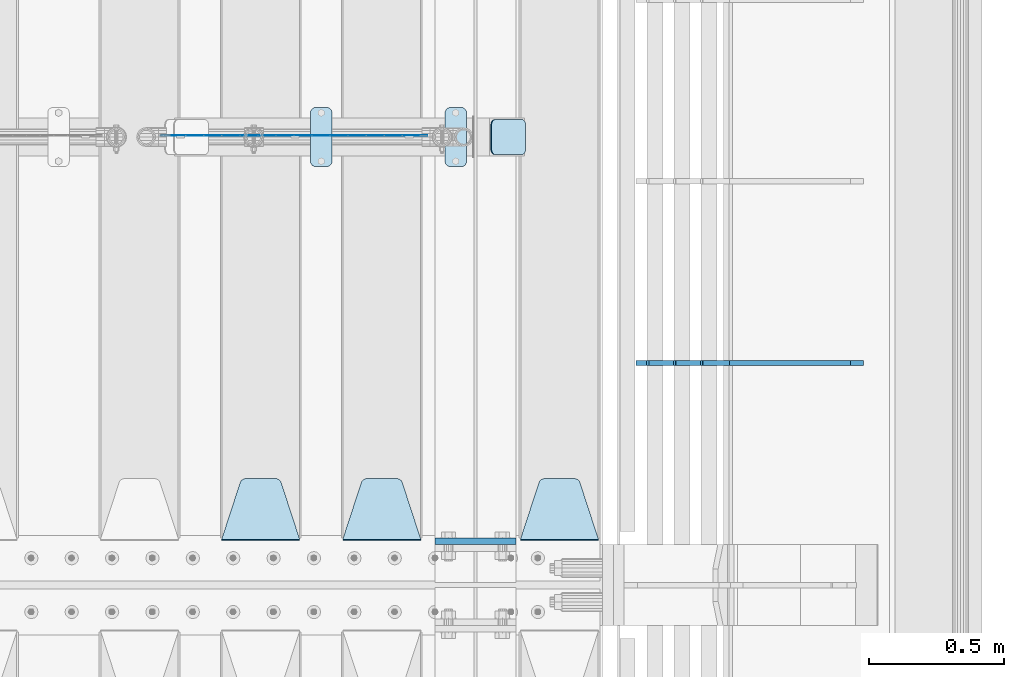
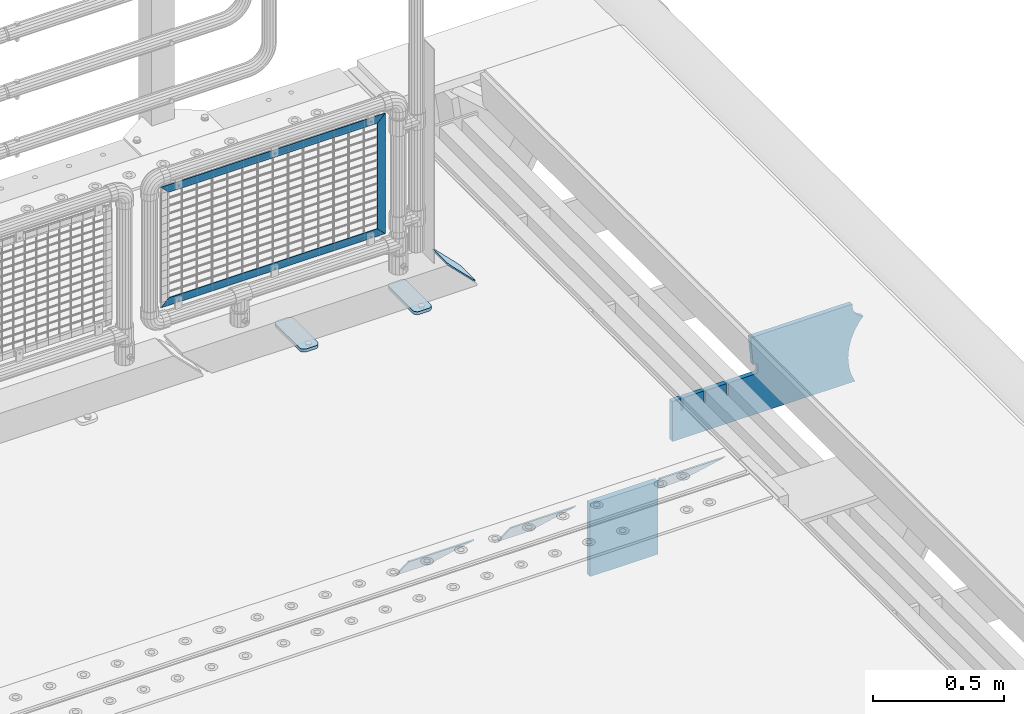
# One storey, part 225 of 242: 11 plates.
"""IFC2X3 building model written with IfcOpenShell, lengths in millimetres."""

import ifcopenshell
import ifcopenshell.guid

model = None  # the IFC model being written
_history = None  # IfcOwnerHistory: only IFC2X3 demands one
_inside = {}  # id of a spatial element -> (the spatial element, [elements in it])
_under = {}  # id of a project, library or spatial element -> (it, [spatial elements below it])
_declared = {}  # id of a project -> (the project, [libraries it declares])
_typed = {}  # id of a type object -> (the type object, [elements of that type])
_made_of = {}  # id of a material, layer set ... -> (it, [elements and type objects made of it])


def new_model(schema):
    """Start an empty IFC model of exactly this schema.

    Asked for "IFC4X3", IfcOpenShell would pick the latest addendum, in which some entities
    have other attributes; the version numbers below select the first issue.
    IFC2X3 requires an IfcOwnerHistory on every rooted entity: one is made here for all.
    """
    global model, _history
    if schema == "IFC4X3":
        model = ifcopenshell.file(schema_version=(4, 3, 0, 0))
    else:
        model = ifcopenshell.file(schema=schema)
    _inside.clear()
    _under.clear()
    _declared.clear()
    _typed.clear()
    _made_of.clear()
    _history = None
    if model.schema == "IFC2X3":
        org = make("IfcOrganization", Name="unknown")
        user = make(
            "IfcPersonAndOrganization",
            ThePerson=make("IfcPerson", FamilyName="unknown"),
            TheOrganization=org,
        )
        app = make(
            "IfcApplication",
            ApplicationDeveloper=org,
            Version="unknown",
            ApplicationFullName="unknown",
            ApplicationIdentifier="unknown",
        )
        _history = make(
            "IfcOwnerHistory",
            OwningUser=user,
            OwningApplication=app,
            ChangeAction="ADDED",
            CreationDate=0,
        )
    return model


def make(cls, **values):
    """One entity of the class cls with the attributes given. An attribute that is None is left unset."""
    return model.create_entity(
        cls, **{name: value for name, value in values.items() if value is not None}
    )


def rooted(cls, **values):
    """An entity with a GlobalId (a new one), such as an element, a storey or a relation."""
    return make(cls, GlobalId=ifcopenshell.guid.new(), OwnerHistory=_history, **values)


def si_unit(unit_type, name, prefix=None):
    """IfcSIUnit, for example si_unit("LENGTHUNIT", "METRE", prefix="MILLI")."""
    return make("IfcSIUnit", UnitType=unit_type, Prefix=prefix, Name=name)


def assignment(units):
    """IfcUnitAssignment: the units of a project."""
    return None if units is None else make("IfcUnitAssignment", Units=units)


def point(xyz):
    """IfcCartesianPoint."""
    return None if xyz is None else make("IfcCartesianPoint", Coordinates=xyz)


def direction(xyz):
    """IfcDirection."""
    return None if xyz is None else make("IfcDirection", DirectionRatios=xyz)


def frame(location, z_axis=None, x_axis=None):
    """IfcAxis2Placement3D, a coordinate frame: its origin and axes. An axis left out is left unset."""
    return make(
        "IfcAxis2Placement3D",
        Location=point(location),
        Axis=direction(z_axis),
        RefDirection=direction(x_axis),
    )


def origin_with_axes():
    """The frame at (0, 0, 0) with the z axis (0, 0, 1) and the x axis (1, 0, 0) written out."""
    return frame((0.0, 0.0, 0.0), z_axis=(0.0, 0.0, 1.0), x_axis=(1.0, 0.0, 0.0))


def place(relative_to, where):
    """IfcLocalPlacement: puts the frame where relative to a parent placement (None: the world)."""
    return make(
        "IfcLocalPlacement", PlacementRelTo=relative_to, RelativePlacement=where
    )


def context(
    kind, dimensions, precision=None, world=None, true_north=None, identifier=None
):
    """IfcGeometricRepresentationContext, for example the 3D "Model" context."""
    return make(
        "IfcGeometricRepresentationContext",
        ContextIdentifier=identifier,
        ContextType=kind,
        CoordinateSpaceDimension=dimensions,
        Precision=precision,
        WorldCoordinateSystem=world,
        TrueNorth=true_north,
    )


def subcontext(parent, identifier, kind, view, scale=None):
    """IfcGeometricRepresentationSubContext, for example "Body" below "Model"."""
    return make(
        "IfcGeometricRepresentationSubContext",
        ContextIdentifier=identifier,
        ContextType=kind,
        ParentContext=parent,
        TargetScale=scale,
        TargetView=view,
    )


def project(units=None, contexts=None):
    """IfcProject with its units and contexts."""
    return rooted(
        "IfcProject",
        Name="project",
        RepresentationContexts=contexts,
        UnitsInContext=assignment(units),
    )


def spatial(cls, under=None, at=None, **own):
    """A site, building, storey or space (cls), placed at a placement, below another one or the project."""
    s = rooted(cls, ObjectPlacement=at, **own)
    if under is not None:
        _under.setdefault(under.id(), (under, []))[1].append(s)
    return s


def faces_of(points, faces, orient=None, outer=None):
    """IfcFace entities. A face is a list of loops; a loop is a list of indices into points, from 0.

    orient and outer hold one flag for each loop. By default every Orientation is true, the
    first loop of a face is its IfcFaceOuterBound and the others are IfcFaceBound.
    """
    made = []
    for i, loops in enumerate(faces):
        bounds = []
        for j, loop in enumerate(loops):
            is_outer = j == 0 if outer is None else outer[i][j]
            bounds.append(
                make(
                    "IfcFaceOuterBound" if is_outer else "IfcFaceBound",
                    Bound=make("IfcPolyLoop", Polygon=[points[k] for k in loop]),
                    Orientation=True if orient is None else orient[i][j],
                )
            )
        made.append(make("IfcFace", Bounds=bounds))
    return made


def faceted_brep(points, faces, orient=None, outer=None, voids=None):
    """IfcFacetedBrep: a solid bounded by flat faces; with voids (closed shells), ...WithVoids."""
    shared = [point(p) for p in points]
    hull = make("IfcClosedShell", CfsFaces=faces_of(shared, faces, orient, outer))
    if voids is None:
        return make("IfcFacetedBrep", Outer=hull)
    return make(
        "IfcFacetedBrepWithVoids",
        Outer=hull,
        Voids=[
            make(cls, CfsFaces=faces_of(shared, fs, o, b)) for cls, fs, o, b in voids
        ],
    )


def shape(context_of_items, identifier, shape_type, items):
    """IfcShapeRepresentation: the items that make up one representation, for example the "Body"."""
    return make(
        "IfcShapeRepresentation",
        ContextOfItems=context_of_items,
        RepresentationIdentifier=identifier,
        RepresentationType=shape_type,
        Items=items,
    )


def material(Name=None, Category=None):
    """IfcMaterial."""
    return make("IfcMaterial", Name=Name, Category=Category)


def made_of(thing, what):
    """Note that an element or type object is made of a material, layer set ...; save() writes the relation."""
    if what is not None:
        _made_of.setdefault(what.id(), (what, []))[1].append(thing)
    return thing


def type_object(cls, material=None, **own):
    """A type object (cls), such as IfcWallType, which elements share."""
    return made_of(rooted(cls, **own), material)


def element(
    cls,
    number,
    at=None,
    inside=None,
    cuts=None,
    type_object=None,
    material=None,
    context=None,
    identifier="Body",
    shape_type=None,
    held_by="IfcProductDefinitionShape",
    body=None,
    shapes=None,
    **own,
):
    """One element of the class cls, such as IfcWall. Its Tag is "e" and its number.

    at: its placement. inside: the storey or other place that contains it. cuts: it is an
    opening in that element (IfcRelVoidsElement). A single representation is given by context,
    identifier, shape_type and body (its items); several are given by shapes. held_by: the class
    of the entity that holds the representations. save() writes the other relations.
    """
    e = rooted(cls, Tag="e%d" % number, ObjectPlacement=at, **own)
    if body is not None:
        shapes = [shape(context, identifier, shape_type, body)]
    if shapes is not None:
        e.Representation = make(held_by, Representations=shapes)
    if inside is not None:
        _inside.setdefault(inside.id(), (inside, []))[1].append(e)
    if cuts is not None:
        rooted(
            "IfcRelVoidsElement", RelatingBuildingElement=cuts, RelatedOpeningElement=e
        )
    if type_object is not None:
        _typed.setdefault(type_object.id(), (type_object, []))[1].append(e)
    return made_of(e, material)


def aggregate(whole, parts):
    """IfcRelAggregates: a whole, such as a stair, and the parts it consists of."""
    return rooted("IfcRelAggregates", RelatingObject=whole, RelatedObjects=parts)


def save(model, path):
    """Write the relations noted so far, then the file.

    IfcRelAggregates (storeys below a building ...), IfcRelContainedInSpatialStructure (elements
    in a storey), IfcRelDefinesByType, IfcRelAssociatesMaterial and IfcRelDeclares: one each for
    every whole, place, type object, material and project.
    """
    for whole, parts in _under.values():
        aggregate(whole, parts)
    for where, things in _inside.values():
        rooted(
            "IfcRelContainedInSpatialStructure",
            RelatedElements=things,
            RelatingStructure=where,
        )
    for kind, things in _typed.values():
        rooted("IfcRelDefinesByType", RelatedObjects=things, RelatingType=kind)
    for what, things in _made_of.values():
        rooted("IfcRelAssociatesMaterial", RelatedObjects=things, RelatingMaterial=what)
    for by, libraries in _declared.values():
        rooted("IfcRelDeclares", RelatingContext=by, RelatedDefinitions=libraries)
    model.write(path)


model = new_model("IFC2X3")

# Units and contexts
model_context = context("Model", 3, precision=1e-05, world=origin_with_axes())
body_context = subcontext(model_context, "Body", "Model", "MODEL_VIEW")
ifc_project = project(units=[si_unit("LENGTHUNIT", "METRE", prefix="MILLI"), si_unit("AREAUNIT", "SQUARE_METRE"), si_unit("VOLUMEUNIT", "CUBIC_METRE"), si_unit("MASSUNIT", "GRAM", prefix="KILO"), si_unit("TIMEUNIT", "SECOND"), si_unit("PLANEANGLEUNIT", "RADIAN"), si_unit("SOLIDANGLEUNIT", "STERADIAN"), si_unit("THERMODYNAMICTEMPERATUREUNIT", "DEGREE_CELSIUS"), si_unit("LUMINOUSINTENSITYUNIT", "LUMEN")], contexts=[model_context])

# Site, building, storey
site_placement = place(None, origin_with_axes())
site = spatial("IfcSite", under=ifc_project, at=site_placement, CompositionType="ELEMENT")
building_placement = place(site_placement, origin_with_axes())
building = spatial("IfcBuilding", under=site, at=building_placement, Name="Standard", CompositionType="ELEMENT")
storey_placement = place(building_placement, origin_with_axes())
storey = spatial("IfcBuildingStorey", under=building, at=storey_placement, Name="Undefined", CompositionType="ELEMENT", Elevation=0.0)

# Plates
ifc_material_1 = material(Name="Misc_Undefined")
plate_type_1 = type_object("IfcPlateType", PredefinedType="NOTDEFINED")
plate_1_placement = place(storey_placement, frame((-23666.8899996664, -19329.5000116708, 386.520006105203), z_axis=(0.707106781186548, 0.0, -0.707106781186548), x_axis=(-0.707106781186548, 0.0, -0.707106781186548)))
element("IfcPlate", 1, at=plate_1_placement, inside=storey, type_object=plate_type_1, material=ifc_material_1, context=body_context, shape_type="Brep", body=[
    faceted_brep([(0.0, -1.50000000000364, 0.0), (-651.521057128926, -1.5, 651.521179199217), (-651.521057128923, 1.5, 651.521179199217), (-3.63797880709171e-12, 1.49999999999636, 0.0), (-651.521057128928, -1.49999999999636, 701.018676757811), (-651.521057128924, 1.50000000000364, 701.018676757809), (49.4974975585974, -1.50000000000364, 1.63709046319127e-11), (49.4974975585938, 1.49999999999636, 1.81898940354586e-11)], [[[0, 1, 2, 3]], [[1, 4, 5, 2]], [[4, 6, 7, 5]], [[6, 0, 3, 7]], [[5, 7, 3, 2]], [[6, 4, 1, 0]]]),
])
plate_2_placement = place(storey_placement, frame((-22710.5000006033, -19329.5002162294, 914.520000514844), z_axis=(-0.707106781186548, 0.0, 0.707106781186548), x_axis=(-0.707106781186548, 0.0, -0.707106781186548)))
element("IfcPlate", 2, at=plate_2_placement, inside=storey, type_object=plate_type_1, material=ifc_material_1, context=body_context, shape_type="Brep", body=[
    faceted_brep([(0.0, -1.50000000000364, 0.0), (701.018554687525, -1.50000000000364, 701.018615722656), (701.018554687527, 1.49999999999636, 701.018615722656), (-3.63797880709171e-12, 1.49999999999636, 0.0), (701.018554687522, -1.50000000000364, 651.521118164059), (701.018554687524, 1.49999999999636, 651.521118164063), (49.4974975585974, -1.50000000000364, 1.63709046319127e-11), (49.4974975585938, 1.49999999999636, 1.81898940354586e-11)], [[[0, 1, 2, 3]], [[1, 4, 5, 2]], [[4, 6, 7, 5]], [[6, 0, 3, 7]], [[5, 7, 3, 2]], [[6, 4, 1, 0]]]),
])
plate_3_placement = place(storey_placement, frame((-22710.5000000138, -19329.5002211987, 914.46146902851), z_axis=(0.706514791587334, 1.30000007553929e-08, -0.707698275586641), x_axis=(-0.70769827558665, 0.0, -0.706514791587325)))
element("IfcPlate", 3, at=plate_3_placement, inside=storey, type_object=plate_type_1, material=ifc_material_1, context=body_context, shape_type="Brep", body=[
    faceted_brep([(0.0, -1.50000000000364, 0.0), (397.726470947269, -1.5, 398.392700195314), (397.726470947269, 1.5, 398.392700195316), (-3.63797880709171e-12, 1.49999999999636, 0.0), (397.767883300783, -1.49999999999636, 348.895263671877), (397.767883300783, 1.50000000000364, 348.895263671879), (49.4561042785626, -1.49999999999636, -4.72937244921923e-11), (49.4561042785626, 1.50000000000364, -4.72937244921923e-11)], [[[0, 1, 2, 3]], [[1, 4, 5, 2]], [[4, 6, 7, 5]], [[6, 0, 3, 7]], [[5, 7, 3, 2]], [[6, 4, 1, 0]]]),
])
ifc_material_2 = material(Name="STEEL/S355J2")
plate_type_2 = type_object("IfcPlateType", PredefinedType="NOTDEFINED")
plate_4_placement = place(storey_placement, frame((-22645.0, -19225.5, 21.0199999999977), z_axis=(1.0, 0.0, 0.0), x_axis=(0.0, -1.0, 0.0)))
element("IfcPlate", 4, at=plate_4_placement, inside=storey, type_object=plate_type_2, material=ifc_material_2, context=body_context, shape_type="Brep", body=[
    faceted_brep([(0.0, -7.0, 20.0), (0.0, -7.0, 60.0), (0.0, 7.0, 60.0), (0.0, 7.0, 20.0), (0.384294391937146, -7.0, 63.9018064403208), (0.384294391937146, 7.0, 63.9018064403208), (1.52240934977453, -7.0, 67.6536686473009), (1.52240934977453, 7.0, 67.6536686473009), (3.37060775395003, -7.0, 71.1114046603907), (3.37060775395003, 7.0, 71.1114046603907), (5.8578643762703, -7.0, 74.1421356237297), (5.8578643762703, 7.0, 74.1421356237297), (8.88859533960931, -7.0, 76.62939224605), (8.88859533960931, 7.0, 76.62939224605), (12.3463313526991, -7.0, 78.4775906502255), (12.3463313526991, 7.0, 78.4775906502255), (16.0981935596792, -7.0, 79.6157056080629), (16.0981935596792, 7.0, 79.6157056080629), (20.0, -7.0, 80.0), (20.0, 7.0, 80.0), (200.0, -7.0, 80.0), (200.0, 7.0, 80.0), (203.901806440321, -7.0, 79.6157056080629), (203.901806440321, 7.0, 79.6157056080629), (207.653668647301, -7.0, 78.4775906502255), (207.653668647301, 7.0, 78.4775906502255), (211.111404660391, -7.0, 76.62939224605), (211.111404660391, 7.0, 76.62939224605), (214.14213562373, -7.0, 74.1421356237297), (214.14213562373, 7.0, 74.1421356237297), (216.62939224605, -7.0, 71.1114046603907), (216.62939224605, 7.0, 71.1114046603907), (218.477590650225, -7.0, 67.6536686473009), (218.477590650225, 7.0, 67.6536686473009), (219.615705608063, -7.0, 63.9018064403208), (219.615705608063, 7.0, 63.9018064403208), (220.0, -7.0, 60.0), (220.0, 7.0, 60.0), (220.0, -7.0, 20.0), (220.0, 7.0, 20.0), (219.615705608063, -7.0, 16.0981935596792), (219.615705608063, 7.0, 16.0981935596792), (218.477590650225, -7.0, 12.3463313526991), (218.477590650225, 7.0, 12.3463313526991), (216.62939224605, -7.0, 8.88859533960931), (216.62939224605, 7.0, 8.88859533960931), (214.14213562373, -7.0, 5.8578643762703), (214.14213562373, 7.0, 5.8578643762703), (211.111404660391, -7.0, 3.37060775395003), (211.111404660391, 7.0, 3.37060775395003), (207.653668647301, -7.0, 1.52240934977453), (207.653668647301, 7.0, 1.52240934977453), (203.901806440321, -7.0, 0.384294391937146), (203.901806440321, 7.0, 0.384294391937146), (200.0, -7.0, 0.0), (200.0, 7.0, 0.0), (20.0, -7.0, 0.0), (20.0, 7.0, 0.0), (16.0981935596792, -7.0, 0.384294391937146), (16.0981935596792, 7.0, 0.384294391937146), (12.3463313526991, -7.0, 1.52240934977453), (12.3463313526991, 7.0, 1.52240934977453), (8.88859533960931, -7.0, 3.37060775395003), (8.88859533960931, 7.0, 3.37060775395003), (5.8578643762703, -7.0, 5.8578643762703), (5.8578643762703, 7.0, 5.8578643762703), (3.37060775395003, -7.0, 8.88859533960931), (3.37060775395003, 7.0, 8.88859533960931), (1.52240934977453, -7.0, 12.3463313526991), (1.52240934977453, 7.0, 12.3463313526991), (0.384294391937146, -7.0, 16.0981935596792), (0.384294391937146, 7.0, 16.0981935596792)], [[[0, 1, 2, 3]], [[1, 4, 5, 2]], [[4, 6, 7, 5]], [[6, 8, 9, 7]], [[8, 10, 11, 9]], [[10, 12, 13, 11]], [[12, 14, 15, 13]], [[14, 16, 17, 15]], [[16, 18, 19, 17]], [[18, 20, 21, 19]], [[20, 22, 23, 21]], [[22, 24, 25, 23]], [[24, 26, 27, 25]], [[26, 28, 29, 27]], [[28, 30, 31, 29]], [[30, 32, 33, 31]], [[32, 34, 35, 33]], [[34, 36, 37, 35]], [[36, 38, 39, 37]], [[38, 40, 41, 39]], [[40, 42, 43, 41]], [[42, 44, 45, 43]], [[44, 46, 47, 45]], [[46, 48, 49, 47]], [[48, 50, 51, 49]], [[50, 52, 53, 51]], [[52, 54, 55, 53]], [[54, 56, 57, 55]], [[56, 58, 59, 57]], [[58, 60, 61, 59]], [[60, 62, 63, 61]], [[62, 64, 65, 63]], [[64, 66, 67, 65]], [[66, 68, 69, 67]], [[68, 70, 71, 69]], [[70, 0, 3, 71]], [[5, 7, 9, 11, 13, 15, 17, 19, 21, 23, 25, 27, 29, 31, 33, 35, 37, 39, 41, 43, 45, 47, 49, 51, 53, 55, 57, 59, 61, 63, 65, 67, 69, 71, 3, 2]], [[70, 68, 66, 64, 62, 60, 58, 56, 54, 52, 50, 48, 46, 44, 42, 40, 38, 36, 34, 32, 30, 28, 26, 24, 22, 20, 18, 16, 14, 12, 10, 8, 6, 4, 1, 0]]]),
])
plate_5_placement = place(storey_placement, frame((-23145.0, -19225.5, 21.0199999999977), z_axis=(1.0, 0.0, 0.0), x_axis=(0.0, -1.0, 0.0)))
element("IfcPlate", 5, at=plate_5_placement, inside=storey, type_object=plate_type_2, material=ifc_material_2, context=body_context, shape_type="Brep", body=[
    faceted_brep([(0.0, -7.0, 20.0), (0.0, -7.0, 60.0), (0.0, 7.0, 60.0), (0.0, 7.0, 20.0), (0.384294391937146, -7.0, 63.9018064403208), (0.384294391937146, 7.0, 63.9018064403208), (1.52240934977453, -7.0, 67.6536686473009), (1.52240934977453, 7.0, 67.6536686473009), (3.37060775395003, -7.0, 71.1114046603907), (3.37060775395003, 7.0, 71.1114046603907), (5.8578643762703, -7.0, 74.1421356237297), (5.8578643762703, 7.0, 74.1421356237297), (8.88859533960931, -7.0, 76.62939224605), (8.88859533960931, 7.0, 76.62939224605), (12.3463313526991, -7.0, 78.4775906502255), (12.3463313526991, 7.0, 78.4775906502255), (16.0981935596792, -7.0, 79.6157056080629), (16.0981935596792, 7.0, 79.6157056080629), (20.0, -7.0, 80.0), (20.0, 7.0, 80.0), (200.0, -7.0, 80.0), (200.0, 7.0, 80.0), (203.901806440321, -7.0, 79.6157056080629), (203.901806440321, 7.0, 79.6157056080629), (207.653668647301, -7.0, 78.4775906502255), (207.653668647301, 7.0, 78.4775906502255), (211.111404660391, -7.0, 76.62939224605), (211.111404660391, 7.0, 76.62939224605), (214.14213562373, -7.0, 74.1421356237297), (214.14213562373, 7.0, 74.1421356237297), (216.62939224605, -7.0, 71.1114046603907), (216.62939224605, 7.0, 71.1114046603907), (218.477590650225, -7.0, 67.6536686473009), (218.477590650225, 7.0, 67.6536686473009), (219.615705608063, -7.0, 63.9018064403208), (219.615705608063, 7.0, 63.9018064403208), (220.0, -7.0, 60.0), (220.0, 7.0, 60.0), (220.0, -7.0, 20.0), (220.0, 7.0, 20.0), (219.615705608063, -7.0, 16.0981935596792), (219.615705608063, 7.0, 16.0981935596792), (218.477590650225, -7.0, 12.3463313526991), (218.477590650225, 7.0, 12.3463313526991), (216.62939224605, -7.0, 8.88859533960931), (216.62939224605, 7.0, 8.88859533960931), (214.14213562373, -7.0, 5.8578643762703), (214.14213562373, 7.0, 5.8578643762703), (211.111404660391, -7.0, 3.37060775395003), (211.111404660391, 7.0, 3.37060775395003), (207.653668647301, -7.0, 1.52240934977453), (207.653668647301, 7.0, 1.52240934977453), (203.901806440321, -7.0, 0.384294391937146), (203.901806440321, 7.0, 0.384294391937146), (200.0, -7.0, 0.0), (200.0, 7.0, 0.0), (20.0, -7.0, 0.0), (20.0, 7.0, 0.0), (16.0981935596792, -7.0, 0.384294391937146), (16.0981935596792, 7.0, 0.384294391937146), (12.3463313526991, -7.0, 1.52240934977453), (12.3463313526991, 7.0, 1.52240934977453), (8.88859533960931, -7.0, 3.37060775395003), (8.88859533960931, 7.0, 3.37060775395003), (5.8578643762703, -7.0, 5.8578643762703), (5.8578643762703, 7.0, 5.8578643762703), (3.37060775395003, -7.0, 8.88859533960931), (3.37060775395003, 7.0, 8.88859533960931), (1.52240934977453, -7.0, 12.3463313526991), (1.52240934977453, 7.0, 12.3463313526991), (0.384294391937146, -7.0, 16.0981935596792), (0.384294391937146, 7.0, 16.0981935596792)], [[[0, 1, 2, 3]], [[1, 4, 5, 2]], [[4, 6, 7, 5]], [[6, 8, 9, 7]], [[8, 10, 11, 9]], [[10, 12, 13, 11]], [[12, 14, 15, 13]], [[14, 16, 17, 15]], [[16, 18, 19, 17]], [[18, 20, 21, 19]], [[20, 22, 23, 21]], [[22, 24, 25, 23]], [[24, 26, 27, 25]], [[26, 28, 29, 27]], [[28, 30, 31, 29]], [[30, 32, 33, 31]], [[32, 34, 35, 33]], [[34, 36, 37, 35]], [[36, 38, 39, 37]], [[38, 40, 41, 39]], [[40, 42, 43, 41]], [[42, 44, 45, 43]], [[44, 46, 47, 45]], [[46, 48, 49, 47]], [[48, 50, 51, 49]], [[50, 52, 53, 51]], [[52, 54, 55, 53]], [[54, 56, 57, 55]], [[56, 58, 59, 57]], [[58, 60, 61, 59]], [[60, 62, 63, 61]], [[62, 64, 65, 63]], [[64, 66, 67, 65]], [[66, 68, 69, 67]], [[68, 70, 71, 69]], [[70, 0, 3, 71]], [[5, 7, 9, 11, 13, 15, 17, 19, 21, 23, 25, 27, 29, 31, 33, 35, 37, 39, 41, 43, 45, 47, 49, 51, 53, 55, 57, 59, 61, 63, 65, 67, 69, 71, 3, 2]], [[70, 68, 66, 64, 62, 60, 58, 56, 54, 52, 50, 48, 46, 44, 42, 40, 38, 36, 34, 32, 30, 28, 26, 24, 22, 20, 18, 16, 14, 12, 10, 8, 6, 4, 1, 0]]]),
])
plate_type_3 = type_object("IfcPlateType", PredefinedType="NOTDEFINED")
plate_6_placement = place(storey_placement, frame((-22473.807581521, -19270.5, 166.254400376567), z_axis=(0.707410512925777, 0.0, -0.706802918925841), x_axis=(0.0, -1.0, 0.0)))
element("IfcPlate", 6, at=plate_6_placement, inside=storey, type_object=plate_type_3, material=ifc_material_2, context=body_context, shape_type="Brep", body=[
    faceted_brep([(0.0, -2.49999999999636, 20.0), (0.0, -2.49999999999636, 158.926651000977), (0.0, 2.50000000000364, 158.926651000977), (0.0, 2.50000000000364, 20.0), (0.384294391937146, -2.49999999999636, 162.828457441301), (0.384294391937146, 2.50000000000364, 162.828457441301), (1.52240934977453, -2.49999999999636, 166.580319648281), (1.52240934977453, 2.50000000000364, 166.580319648281), (3.37060775395003, -2.49999999999636, 170.038055661371), (3.37060775395003, 2.50000000000364, 170.038055661371), (5.8578643762703, -2.49999999999636, 173.068786624706), (5.8578643762703, 2.50000000000364, 173.06878662471), (8.88859533960931, -2.5, 175.55604324703), (8.88859533960931, 2.50000000000364, 175.55604324703), (12.3463313526991, -2.49999999999636, 177.404241651206), (12.3463313526991, 2.50000000000364, 177.404241651206), (16.0981935596792, -2.49999999999636, 178.542356609043), (16.0981935596792, 2.50000000000728, 178.542356609043), (20.0, -2.49999999999272, 178.926651000977), (20.0, 2.50000000000364, 178.92665100098), (110.0, -2.49999999999272, 178.926651000977), (110.0, 2.50000000000364, 178.92665100098), (113.901806440321, -2.49999999999636, 178.542356609043), (113.901806440321, 2.50000000000728, 178.542356609043), (117.653668647301, -2.49999999999636, 177.404241651206), (117.653668647301, 2.50000000000364, 177.404241651206), (121.111404660391, -2.5, 175.55604324703), (121.111404660391, 2.50000000000364, 175.55604324703), (124.14213562373, -2.49999999999636, 173.068786624706), (124.14213562373, 2.50000000000364, 173.06878662471), (126.62939224605, -2.49999999999636, 170.038055661371), (126.62939224605, 2.50000000000364, 170.038055661371), (128.477590650225, -2.49999999999636, 166.580319648281), (128.477590650225, 2.50000000000364, 166.580319648281), (129.615705608063, -2.49999999999636, 162.828457441301), (129.615705608063, 2.50000000000364, 162.828457441301), (130.0, -2.49999999999636, 158.926651000977), (130.0, 2.50000000000364, 158.926651000977), (130.0, -2.49999999999636, 20.0), (130.0, 2.50000000000364, 20.0), (129.615705608063, -2.49999999999636, 16.0981935596792), (129.615705608063, 2.50000000000364, 16.0981935596792), (128.477590650225, -2.49999999999636, 12.3463313526991), (128.477590650225, 2.50000000000364, 12.3463313526991), (126.62939224605, -2.49999999999636, 8.88859533961295), (126.62939224605, 2.5, 8.88859533960931), (124.14213562373, -2.49999999999636, 5.8578643762703), (124.14213562373, 2.5, 5.8578643762703), (121.111404660391, -2.49999999999636, 3.37060775395003), (121.111404660391, 2.50000000000364, 3.37060775395003), (117.653668647301, -2.49999999999636, 1.52240934977453), (117.653668647301, 2.50000000000364, 1.52240934977453), (113.901806440321, -2.49999999999636, 0.384294391933508), (113.901806440321, 2.50000000000364, 0.384294391937146), (110.0, -2.49999999999636, 3.63797880709171e-12), (110.0, 2.50000000000728, 3.63797880709171e-12), (20.0, -2.49999999999636, 3.63797880709171e-12), (20.0, 2.50000000000728, 3.63797880709171e-12), (16.0981935596792, -2.49999999999636, 0.384294391933508), (16.0981935596792, 2.50000000000364, 0.384294391937146), (12.3463313526991, -2.49999999999636, 1.52240934977453), (12.3463313526991, 2.50000000000364, 1.52240934977453), (8.88859533960931, -2.49999999999636, 3.37060775395003), (8.88859533960931, 2.50000000000364, 3.37060775395003), (5.8578643762703, -2.49999999999636, 5.8578643762703), (5.8578643762703, 2.5, 5.8578643762703), (3.37060775395003, -2.49999999999636, 8.88859533961295), (3.37060775395003, 2.5, 8.88859533960931), (1.52240934977453, -2.49999999999636, 12.3463313526991), (1.52240934977453, 2.50000000000364, 12.3463313526991), (0.384294391937146, -2.49999999999636, 16.0981935596792), (0.384294391937146, 2.50000000000364, 16.0981935596792)], [[[0, 1, 2, 3]], [[1, 4, 5, 2]], [[4, 6, 7, 5]], [[6, 8, 9, 7]], [[8, 10, 11, 9]], [[10, 12, 13, 11]], [[12, 14, 15, 13]], [[14, 16, 17, 15]], [[16, 18, 19, 17]], [[18, 20, 21, 19]], [[20, 22, 23, 21]], [[22, 24, 25, 23]], [[24, 26, 27, 25]], [[26, 28, 29, 27]], [[28, 30, 31, 29]], [[30, 32, 33, 31]], [[32, 34, 35, 33]], [[34, 36, 37, 35]], [[36, 38, 39, 37]], [[38, 40, 41, 39]], [[40, 42, 43, 41]], [[42, 44, 45, 43]], [[44, 46, 47, 45]], [[46, 48, 49, 47]], [[48, 50, 51, 49]], [[50, 52, 53, 51]], [[52, 54, 55, 53]], [[54, 56, 57, 55]], [[56, 58, 59, 57]], [[58, 60, 61, 59]], [[60, 62, 63, 61]], [[62, 64, 65, 63]], [[64, 66, 67, 65]], [[66, 68, 69, 67]], [[68, 70, 71, 69]], [[70, 0, 3, 71]], [[5, 7, 9, 11, 13, 15, 17, 19, 21, 23, 25, 27, 29, 31, 33, 35, 37, 39, 41, 43, 45, 47, 49, 51, 53, 55, 57, 59, 61, 63, 65, 67, 69, 71, 3, 2]], [[70, 68, 66, 64, 62, 60, 58, 56, 54, 52, 50, 48, 46, 44, 42, 40, 38, 36, 34, 32, 30, 28, 26, 24, 22, 20, 18, 16, 14, 12, 10, 8, 6, 4, 1, 0]]]),
])
ifc_material_3 = material(Name="STEEL/S355N")
plate_type_4 = type_object("IfcPlateType", PredefinedType="NOTDEFINED")
plate_7_placement = place(storey_placement, frame((-22682.0, -20837.5, -340.000000000044), z_axis=(0.0, 0.0, 1.0), x_axis=(1.0, 0.0, 0.0)))
element("IfcPlate", 7, at=plate_7_placement, inside=storey, type_object=plate_type_4, material=ifc_material_3, context=body_context, shape_type="Brep", body=[
    faceted_brep([(0.0, -12.5, 0.0), (9.27684595808387e-10, -12.5, 340.0), (9.27684595808387e-10, 12.5, 340.0), (0.0, 12.5, 0.0), (300.0, -12.5, 340.0), (300.0, 12.5, 340.0), (300.0, -12.5, 0.0), (300.0, 12.5, 0.0)], [[[0, 1, 2, 3]], [[1, 4, 5, 2]], [[4, 6, 7, 5]], [[6, 0, 3, 7]], [[5, 7, 3, 2]], [[6, 4, 1, 0]]]),
])
plate_type_5 = type_object("IfcPlateType", PredefinedType="NOTDEFINED")
plate_8_placement = place(storey_placement, frame((-22075.0, -20831.767766953, -1.76776695296758), z_axis=(0.0, 0.707106781186547, -0.707106781186548), x_axis=(-1.0, 0.0, 0.0)))
element("IfcPlate", 8, at=plate_8_placement, inside=storey, type_object=plate_type_5, material=ifc_material_3, context=body_context, shape_type="Brep", body=[
    faceted_brep([(0.0, -2.5, 0.0), (69.345504679477, -2.50000000000182, 300.171731424829), (69.345504679477, 2.5, 300.171731424829), (0.0, 2.5, 0.0), (70.9274061199576, -2.5, 304.897442415398), (70.9274061199576, 2.5, 304.897442415398), (73.3818627772307, -2.5, 309.234538108525), (73.3818627772307, 2.50000000000182, 309.234538108529), (76.6187032999551, -2.5, 313.023683126101), (76.6187032999551, 2.50000000000182, 313.023683126103), (80.5190132704993, -2.5, 316.12567259537), (80.5190132704993, 2.5, 316.12567259537), (84.9395038596849, -2.5, 318.426546230474), (84.9395038596849, 2.50000000000182, 318.426546230476), (89.7177759439219, -2.49999999999818, 319.841774983273), (89.7177759439219, 2.50000000000182, 319.841774983273), (94.678286292652, -2.5, 320.319366455076), (94.678286292652, 2.5, 320.319366455076), (195.321713707348, -2.5, 320.319366455076), (195.321713707348, 2.5, 320.319366455076), (200.282224056078, -2.5, 319.841774983272), (200.282224056078, 2.50000000000182, 319.841774983273), (205.060496140315, -2.5, 318.426546230474), (205.060496140315, 2.49999999999818, 318.426546230474), (209.480986729501, -2.49999999999818, 316.12567259537), (209.480986729501, 2.5, 316.12567259537), (213.381296700045, -2.5, 313.023683126101), (213.381296700045, 2.49999999999818, 313.023683126101), (216.618137222769, -2.5, 309.234538108525), (216.618137222769, 2.5, 309.234538108523), (219.072593880042, -2.49999999999818, 304.897442415398), (219.072593880042, 2.50000000000182, 304.897442415398), (220.654495320523, -2.50000000000182, 300.171731424829), (220.654495320523, 2.5, 300.171731424829), (290.0, -2.5, 0.0), (290.0, 2.5, -1.81898940354586e-12)], [[[0, 1, 2, 3]], [[1, 4, 5, 2]], [[4, 6, 7, 5]], [[6, 8, 9, 7]], [[8, 10, 11, 9]], [[10, 12, 13, 11]], [[12, 14, 15, 13]], [[14, 16, 17, 15]], [[16, 18, 19, 17]], [[18, 20, 21, 19]], [[20, 22, 23, 21]], [[22, 24, 25, 23]], [[24, 26, 27, 25]], [[26, 28, 29, 27]], [[28, 30, 31, 29]], [[30, 32, 33, 31]], [[32, 34, 35, 33]], [[34, 0, 3, 35]], [[5, 7, 9, 11, 13, 15, 17, 19, 21, 23, 25, 27, 29, 31, 33, 35, 3, 2]], [[34, 32, 30, 28, 26, 24, 22, 20, 18, 16, 14, 12, 10, 8, 6, 4, 1, 0]]]),
])
plate_9_placement = place(storey_placement, frame((-22735.0, -20831.767766953, -1.76776695296758), z_axis=(0.0, 0.707106781186547, -0.707106781186548), x_axis=(-1.0, 0.0, 0.0)))
element("IfcPlate", 9, at=plate_9_placement, inside=storey, type_object=plate_type_5, material=ifc_material_3, context=body_context, shape_type="Brep", body=[
    faceted_brep([(0.0, -2.5, 0.0), (69.345504679477, -2.50000000000182, 300.171731424829), (69.345504679477, 2.5, 300.171731424829), (0.0, 2.5, 0.0), (70.9274061199576, -2.5, 304.897442415398), (70.9274061199576, 2.5, 304.897442415398), (73.3818627772307, -2.5, 309.234538108525), (73.3818627772307, 2.50000000000182, 309.234538108529), (76.6187032999551, -2.5, 313.023683126101), (76.6187032999551, 2.50000000000182, 313.023683126103), (80.5190132704993, -2.5, 316.12567259537), (80.5190132704993, 2.5, 316.12567259537), (84.9395038596849, -2.5, 318.426546230474), (84.9395038596849, 2.50000000000182, 318.426546230476), (89.7177759439219, -2.49999999999818, 319.841774983273), (89.7177759439219, 2.50000000000182, 319.841774983273), (94.678286292652, -2.5, 320.319366455076), (94.678286292652, 2.5, 320.319366455076), (195.321713707348, -2.5, 320.319366455076), (195.321713707348, 2.5, 320.319366455076), (200.282224056078, -2.5, 319.841774983272), (200.282224056078, 2.50000000000182, 319.841774983273), (205.060496140315, -2.5, 318.426546230474), (205.060496140315, 2.49999999999818, 318.426546230474), (209.480986729501, -2.49999999999818, 316.12567259537), (209.480986729501, 2.5, 316.12567259537), (213.381296700045, -2.5, 313.023683126101), (213.381296700045, 2.49999999999818, 313.023683126101), (216.618137222769, -2.5, 309.234538108525), (216.618137222769, 2.5, 309.234538108523), (219.072593880042, -2.49999999999818, 304.897442415398), (219.072593880042, 2.50000000000182, 304.897442415398), (220.654495320523, -2.50000000000182, 300.171731424829), (220.654495320523, 2.5, 300.171731424829), (290.0, -2.5, 0.0), (290.0, 2.5, -1.81898940354586e-12)], [[[0, 1, 2, 3]], [[1, 4, 5, 2]], [[4, 6, 7, 5]], [[6, 8, 9, 7]], [[8, 10, 11, 9]], [[10, 12, 13, 11]], [[12, 14, 15, 13]], [[14, 16, 17, 15]], [[16, 18, 19, 17]], [[18, 20, 21, 19]], [[20, 22, 23, 21]], [[22, 24, 25, 23]], [[24, 26, 27, 25]], [[26, 28, 29, 27]], [[28, 30, 31, 29]], [[30, 32, 33, 31]], [[32, 34, 35, 33]], [[34, 0, 3, 35]], [[5, 7, 9, 11, 13, 15, 17, 19, 21, 23, 25, 27, 29, 31, 33, 35, 3, 2]], [[34, 32, 30, 28, 26, 24, 22, 20, 18, 16, 14, 12, 10, 8, 6, 4, 1, 0]]]),
])
plate_10_placement = place(storey_placement, frame((-23185.0, -20831.767766953, -1.76776695296758), z_axis=(0.0, 0.707106781186547, -0.707106781186548), x_axis=(-1.0, 0.0, 0.0)))
element("IfcPlate", 10, at=plate_10_placement, inside=storey, type_object=plate_type_5, material=ifc_material_3, context=body_context, shape_type="Brep", body=[
    faceted_brep([(0.0, -2.5, 0.0), (69.345504679477, -2.50000000000182, 300.171731424829), (69.345504679477, 2.5, 300.171731424829), (0.0, 2.5, 0.0), (70.9274061199576, -2.5, 304.897442415398), (70.9274061199576, 2.5, 304.897442415398), (73.3818627772307, -2.5, 309.234538108525), (73.3818627772307, 2.50000000000182, 309.234538108529), (76.6187032999551, -2.5, 313.023683126101), (76.6187032999551, 2.50000000000182, 313.023683126103), (80.5190132704993, -2.5, 316.12567259537), (80.5190132704993, 2.5, 316.12567259537), (84.9395038596849, -2.5, 318.426546230474), (84.9395038596849, 2.50000000000182, 318.426546230476), (89.7177759439219, -2.49999999999818, 319.841774983273), (89.7177759439219, 2.50000000000182, 319.841774983273), (94.678286292652, -2.5, 320.319366455076), (94.678286292652, 2.5, 320.319366455076), (195.321713707348, -2.5, 320.319366455076), (195.321713707348, 2.5, 320.319366455076), (200.282224056078, -2.5, 319.841774983272), (200.282224056078, 2.50000000000182, 319.841774983273), (205.060496140315, -2.5, 318.426546230474), (205.060496140315, 2.49999999999818, 318.426546230474), (209.480986729501, -2.49999999999818, 316.12567259537), (209.480986729501, 2.5, 316.12567259537), (213.381296700045, -2.5, 313.023683126101), (213.381296700045, 2.49999999999818, 313.023683126101), (216.618137222769, -2.5, 309.234538108525), (216.618137222769, 2.5, 309.234538108523), (219.072593880042, -2.49999999999818, 304.897442415398), (219.072593880042, 2.50000000000182, 304.897442415398), (220.654495320523, -2.50000000000182, 300.171731424829), (220.654495320523, 2.5, 300.171731424829), (290.0, -2.5, 0.0), (290.0, 2.5, -1.81898940354586e-12)], [[[0, 1, 2, 3]], [[1, 4, 5, 2]], [[4, 6, 7, 5]], [[6, 8, 9, 7]], [[8, 10, 11, 9]], [[10, 12, 13, 11]], [[12, 14, 15, 13]], [[14, 16, 17, 15]], [[16, 18, 19, 17]], [[18, 20, 21, 19]], [[20, 22, 23, 21]], [[22, 24, 25, 23]], [[24, 26, 27, 25]], [[26, 28, 29, 27]], [[28, 30, 31, 29]], [[30, 32, 33, 31]], [[32, 34, 35, 33]], [[34, 0, 3, 35]], [[5, 7, 9, 11, 13, 15, 17, 19, 21, 23, 25, 27, 29, 31, 33, 35, 3, 2]], [[34, 32, 30, 28, 26, 24, 22, 20, 18, 16, 14, 12, 10, 8, 6, 4, 1, 0]]]),
])
plate_type_6 = type_object("IfcPlateType", PredefinedType="NOTDEFINED")
plate_11_placement = place(storey_placement, frame((-21094.0817660324, -20175.0007171631, -374.002067436516), z_axis=(0.0, 0.0, 1.0), x_axis=(-1.0, 0.0, 0.0)))
element("IfcPlate", 11, at=plate_11_placement, inside=storey, type_object=plate_type_6, material=ifc_material_3, context=body_context, shape_type="Brep", body=[
    faceted_brep([(801.919404066546, -10.0, 188.0), (801.919404066546, 10.0, 188.0), (801.919404066546, 10.0, 132.002067436952), (801.919404066546, -10.0, 132.002067436952), (793.919404066546, 10.0, 132.002067436952), (793.919404066546, -10.0, 132.002067436952), (793.919404066546, 10.0, 180.002067436952), (793.919404066546, -10.0, 180.002067436952), (793.527856196906, 10.0, 182.474203391951), (793.527856196906, -10.0, 182.474203391951), (792.391540021545, 10.0, 184.704349455291), (792.391540021545, -10.0, 184.704349455291), (790.621686084887, 10.0, 186.474203391951), (790.621686084887, -10.0, 186.474203391951), (788.391540021545, 10.0, 187.610519567313), (788.391540021545, -10.0, 187.610519567313), (785.919404066546, -10.0, 188.002067436952), (785.919404066546, 10.0, 188.0), (841.0, -10.0, 188.0), (841.0, -10.0, 0.0), (841.0, 10.0, 0.0), (841.0, 10.0, 188.0), (33.3619566735979, -10.0, 0.0), (33.3619566735979, 10.0, 0.0), (36.2350612208174, -10.0, 4.68848050267007), (36.2350612208174, 10.0, 4.68848050267007), (51.4877592159428, -10.0, 41.5117508652783), (51.4877592159428, 10.0, 41.5117508652783), (60.792242588137, -10.0, 80.2677133162963), (60.792242588137, 10.0, 80.2677133162963), (63.9194040769726, -10.0, 120.002067436515), (63.9194040769726, 10.0, 120.002067436515), (60.792242588137, -10.0, 159.736421556734), (60.792242588137, 10.0, 159.736421556734), (51.4877592159428, -10.0, 198.492384007752), (51.4877592159428, 10.0, 198.492384007752), (36.2350612208174, -10.0, 235.31565437036), (36.2350612208174, 10.0, 235.31565437036), (15.4097206482074, -10.0, 269.299521518803), (15.4097206482074, 10.0, 269.299521518803), (-3.35474438098754, -10.0, 291.269887256574), (-3.35474438098754, 10.0, 291.269887256574), (-2.36881039375294, -10.0, 291.426043859339), (-2.36881039375294, 10.0, 291.426043859339), (17.1449676604716, -10.0, 301.368810393754), (17.1449676604716, 10.0, 301.368810393754), (32.6311896062471, -10.0, 316.855032339527), (32.6311896062471, 10.0, 316.855032339527), (42.573956140659, -10.0, 336.368810393754), (42.573956140659, 10.0, 336.368810393754), (46.0, -10.0, 358.0), (46.0, 10.0, 358.0), (45.0495205499137, -10.0, 364.001091067617), (45.0495205499137, 10.0, 364.001091067617), (495.040008544922, -10.0, 364.010009765625), (495.040008544922, 10.0, 364.010009765625), (483.600036621094, -10.0, 233.759994506836), (483.600036621094, 10.0, 233.759994506836), (472.0, -10.0, 233.759994506836), (472.0, 10.0, 233.759994506836), (468.909830056251, -10.0, 233.270559669787), (468.909830056251, 10.0, 233.270559669787), (466.122147477075, -10.0, 231.850164450585), (466.122147477075, 10.0, 231.850164450585), (463.909830056251, -10.0, 229.637847029761), (463.909830056251, 10.0, 229.637847029761), (462.489434837047, -10.0, 226.850164450585), (462.489434837047, 10.0, 226.850164450585), (462.0, -10.0, 223.759994506836), (462.0, 10.0, 223.759994506836), (462.0, -10.0, 198.0), (462.0, 10.0, 198.0), (462.489434837047, -10.0, 194.909830056251), (462.489434837047, 10.0, 194.909830056251), (463.909830056251, -10.0, 192.122147477075), (463.909830056251, 10.0, 192.122147477075), (466.122147477075, -10.0, 189.909830056251), (466.122147477075, 10.0, 189.909830056251), (468.909830056251, -10.0, 188.489434837048), (468.909830056251, 10.0, 188.489434837048), (472.0, -10.0, 188.0), (472.0, 10.0, 188.0), (585.919404066546, -10.0, 188.002067436952), (585.919404066546, 10.0, 188.0), (588.391540021545, -10.0, 187.610519567313), (588.391540021545, 10.0, 187.610519567313), (590.621686084887, -10.0, 186.474203391951), (590.621686084887, 10.0, 186.474203391951), (592.391540021545, -10.0, 184.704349455291), (592.391540021545, 10.0, 184.704349455291), (593.527856196906, -10.0, 182.474203391951), (593.527856196906, 10.0, 182.474203391951), (593.919404066546, -10.0, 180.002067436952), (593.919404066546, 10.0, 180.002067436952), (593.919404066546, -10.0000000000036, 132.002067436952), (593.919404066546, 10.0, 132.002067436952), (601.919404066546, -10.0000000000036, 132.002067436952), (601.919404066546, 10.0, 132.002067436952), (601.919404066546, -10.0, 188.0), (601.919404066546, 10.0, 188.0), (685.919404066546, -10.0, 188.002067436952), (685.919404066546, 10.0, 188.0), (688.391540021545, -10.0, 187.610519567313), (688.391540021545, 10.0, 187.610519567313), (690.621686084887, -10.0, 186.474203391951), (690.621686084887, 10.0, 186.474203391951), (692.391540021545, -10.0, 184.704349455291), (692.391540021545, 10.0, 184.704349455291), (693.527856196906, -10.0, 182.474203391951), (693.527856196906, 10.0, 182.474203391951), (693.919404066546, -10.0, 180.002067436952), (693.919404066546, 10.0, 180.002067436952), (693.919404066546, -10.0, 132.002067436952), (693.919404066546, 10.0, 132.002067436952), (701.919404066546, -10.0, 132.002067436952), (701.919404066546, 10.0, 132.002067436952), (701.919404066546, -10.0, 188.0), (701.919404066546, 10.0, 188.0)], [[[0, 1, 2, 3]], [[3, 2, 4, 5]], [[5, 4, 6, 7]], [[7, 6, 8, 9]], [[9, 8, 10, 11]], [[11, 10, 12, 13]], [[13, 12, 14, 15]], [[16, 15, 14, 17]], [[18, 19, 20, 21]], [[20, 19, 22, 23]], [[22, 24, 25, 23]], [[26, 27, 25, 24]], [[28, 29, 27, 26]], [[30, 31, 29, 28]], [[32, 33, 31, 30]], [[34, 35, 33, 32]], [[36, 37, 35, 34]], [[38, 39, 37, 36]], [[39, 38, 40, 41]], [[40, 42, 43, 41]], [[44, 45, 43, 42]], [[46, 47, 45, 44]], [[48, 49, 47, 46]], [[50, 51, 49, 48]], [[52, 53, 51, 50]], [[54, 55, 53, 52]], [[54, 56, 57, 55]], [[56, 58, 59, 57]], [[58, 60, 61, 59]], [[60, 62, 63, 61]], [[62, 64, 65, 63]], [[64, 66, 67, 65]], [[66, 68, 69, 67]], [[68, 70, 71, 69]], [[70, 72, 73, 71]], [[72, 74, 75, 73]], [[74, 76, 77, 75]], [[76, 78, 79, 77]], [[78, 80, 81, 79]], [[81, 80, 82, 83]], [[82, 84, 85, 83]], [[86, 87, 85, 84]], [[88, 89, 87, 86]], [[90, 91, 89, 88]], [[92, 93, 91, 90]], [[94, 95, 93, 92]], [[96, 97, 95, 94]], [[98, 99, 97, 96]], [[99, 98, 100, 101]], [[100, 102, 103, 101]], [[104, 105, 103, 102]], [[106, 107, 105, 104]], [[108, 109, 107, 106]], [[110, 111, 109, 108]], [[112, 113, 111, 110]], [[114, 115, 113, 112]], [[116, 117, 115, 114]], [[117, 116, 16, 17]], [[12, 10, 8, 6, 4, 2, 1, 21, 20, 23, 25, 27, 29, 31, 33, 35, 37, 39, 41, 43, 45, 47, 49, 51, 53, 55, 57, 59, 61, 63, 65, 67, 69, 71, 73, 75, 77, 79, 81, 83, 85, 87, 89, 91, 93, 95, 97, 99, 101, 103, 105, 107, 109, 111, 113, 115, 117, 17, 14]], [[18, 21, 1, 0]], [[116, 114, 112, 110, 108, 106, 104, 102, 100, 98, 96, 94, 92, 90, 88, 86, 84, 82, 80, 78, 76, 74, 72, 70, 68, 66, 64, 62, 60, 58, 56, 54, 52, 50, 48, 46, 44, 42, 40, 38, 36, 34, 32, 30, 28, 26, 24, 22, 19, 18, 0, 3, 5, 7, 9, 11, 13, 15, 16]]]),
])

save(model, "model.ifc")
